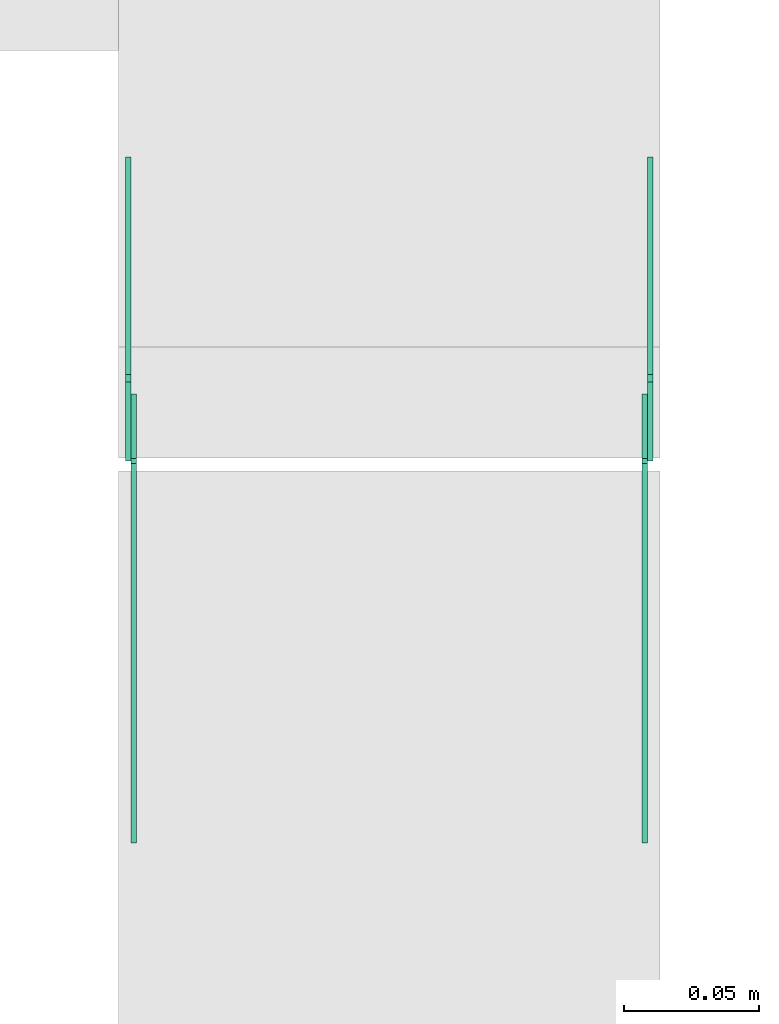
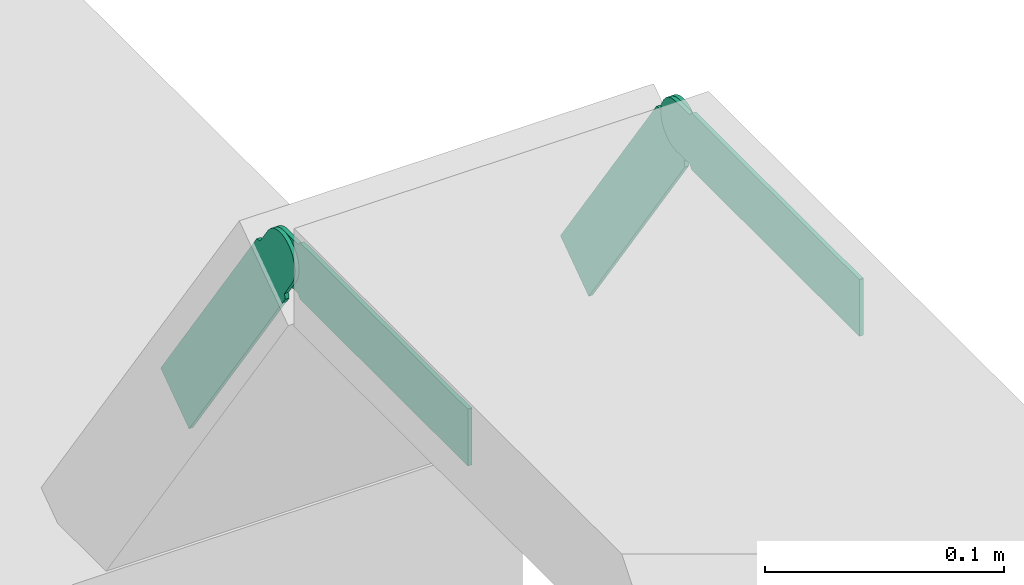
# One storey, part 26 of 28: 4 flow fittings.
"""IFC2X3 building model written with IfcOpenShell, lengths in millimetres."""

import ifcopenshell
import ifcopenshell.guid

model = None  # the IFC model being written
_history = None  # IfcOwnerHistory: only IFC2X3 demands one
_inside = {}  # id of a spatial element -> (the spatial element, [elements in it])
_under = {}  # id of a project, library or spatial element -> (it, [spatial elements below it])
_declared = {}  # id of a project -> (the project, [libraries it declares])
_typed = {}  # id of a type object -> (the type object, [elements of that type])
_made_of = {}  # id of a material, layer set ... -> (it, [elements and type objects made of it])


def new_model(schema):
    """Start an empty IFC model of exactly this schema.

    Asked for "IFC4X3", IfcOpenShell would pick the latest addendum, in which some entities
    have other attributes; the version numbers below select the first issue.
    IFC2X3 requires an IfcOwnerHistory on every rooted entity: one is made here for all.
    """
    global model, _history
    if schema == "IFC4X3":
        model = ifcopenshell.file(schema_version=(4, 3, 0, 0))
    else:
        model = ifcopenshell.file(schema=schema)
    _inside.clear()
    _under.clear()
    _declared.clear()
    _typed.clear()
    _made_of.clear()
    _history = None
    if model.schema == "IFC2X3":
        org = make("IfcOrganization", Name="unknown")
        user = make(
            "IfcPersonAndOrganization",
            ThePerson=make("IfcPerson", FamilyName="unknown"),
            TheOrganization=org,
        )
        app = make(
            "IfcApplication",
            ApplicationDeveloper=org,
            Version="unknown",
            ApplicationFullName="unknown",
            ApplicationIdentifier="unknown",
        )
        _history = make(
            "IfcOwnerHistory",
            OwningUser=user,
            OwningApplication=app,
            ChangeAction="ADDED",
            CreationDate=0,
        )
    return model


def make(cls, **values):
    """One entity of the class cls with the attributes given. An attribute that is None is left unset."""
    return model.create_entity(
        cls, **{name: value for name, value in values.items() if value is not None}
    )


def entity(cls, *values):
    """Any entity or typed value of the class cls, its attributes in the order of the schema. None: left unset."""
    e = model.create_entity(cls)
    for i, value in enumerate(values):
        if value is not None:
            e[i] = value
    return e


def rooted(cls, **values):
    """An entity with a GlobalId (a new one), such as an element, a storey or a relation."""
    return make(cls, GlobalId=ifcopenshell.guid.new(), OwnerHistory=_history, **values)


def si_unit(unit_type, name, prefix=None):
    """IfcSIUnit, for example si_unit("LENGTHUNIT", "METRE", prefix="MILLI")."""
    return make("IfcSIUnit", UnitType=unit_type, Prefix=prefix, Name=name)


def converted_unit(unit_type, name, factor, base, dimensions=None, offset=None):
    """IfcConversionBasedUnit, such as the inch: factor (a typed value) times the base unit."""
    return make(
        "IfcConversionBasedUnit"
        if offset is None
        else "IfcConversionBasedUnitWithOffset",
        ConversionOffset=offset,
        Dimensions=None
        if dimensions is None
        else entity("IfcDimensionalExponents", *dimensions),
        UnitType=unit_type,
        Name=name,
        ConversionFactor=make(
            "IfcMeasureWithUnit", ValueComponent=factor, UnitComponent=base
        ),
    )


def derived_unit(unit_type, elements):
    """IfcDerivedUnit: a product of units, each with its exponent."""
    return make(
        "IfcDerivedUnit",
        Elements=[
            make("IfcDerivedUnitElement", Unit=unit, Exponent=power)
            for unit, power in elements
        ],
        UnitType=unit_type,
    )


def assignment(units):
    """IfcUnitAssignment: the units of a project."""
    return None if units is None else make("IfcUnitAssignment", Units=units)


def point(xyz):
    """IfcCartesianPoint."""
    return None if xyz is None else make("IfcCartesianPoint", Coordinates=xyz)


def direction(xyz):
    """IfcDirection."""
    return None if xyz is None else make("IfcDirection", DirectionRatios=xyz)


def frame(location, z_axis=None, x_axis=None):
    """IfcAxis2Placement3D, a coordinate frame: its origin and axes. An axis left out is left unset."""
    return make(
        "IfcAxis2Placement3D",
        Location=point(location),
        Axis=direction(z_axis),
        RefDirection=direction(x_axis),
    )


def frame_2d(location, x_axis=None):
    """IfcAxis2Placement2D, a coordinate frame in the plane: its origin and x axis."""
    return make(
        "IfcAxis2Placement2D", Location=point(location), RefDirection=direction(x_axis)
    )


def origin():
    """The frame at (0, 0, 0) with its axes left unset."""
    return frame((0.0, 0.0, 0.0))


def place(relative_to, where):
    """IfcLocalPlacement: puts the frame where relative to a parent placement (None: the world)."""
    return make(
        "IfcLocalPlacement", PlacementRelTo=relative_to, RelativePlacement=where
    )


def context(
    kind, dimensions, precision=None, world=None, true_north=None, identifier=None
):
    """IfcGeometricRepresentationContext, for example the 3D "Model" context."""
    return make(
        "IfcGeometricRepresentationContext",
        ContextIdentifier=identifier,
        ContextType=kind,
        CoordinateSpaceDimension=dimensions,
        Precision=precision,
        WorldCoordinateSystem=world,
        TrueNorth=true_north,
    )


def subcontext(parent, identifier, kind, view, scale=None):
    """IfcGeometricRepresentationSubContext, for example "Body" below "Model"."""
    return make(
        "IfcGeometricRepresentationSubContext",
        ContextIdentifier=identifier,
        ContextType=kind,
        ParentContext=parent,
        TargetScale=scale,
        TargetView=view,
    )


def project(units=None, contexts=None):
    """IfcProject with its units and contexts."""
    return rooted(
        "IfcProject",
        Name="project",
        RepresentationContexts=contexts,
        UnitsInContext=assignment(units),
    )


def spatial(cls, under=None, at=None, **own):
    """A site, building, storey or space (cls), placed at a placement, below another one or the project."""
    s = rooted(cls, ObjectPlacement=at, **own)
    if under is not None:
        _under.setdefault(under.id(), (under, []))[1].append(s)
    return s


def polyline(points):
    """IfcPolyline through the points."""
    return make("IfcPolyline", Points=[point(p) for p in points])


def circle_curve(where, radius):
    """IfcCircle in the frame where."""
    return make("IfcCircle", Position=where, Radius=radius)


def parameter(value):
    """IfcParameterValue: where a trimmed curve begins or ends, as a parameter of its basis curve."""
    return model.create_entity("IfcParameterValue", value)


def trimmed(basis, trim1, trim2, sense, master):
    """IfcTrimmedCurve: the piece of a basis curve between two trims."""
    return make(
        "IfcTrimmedCurve",
        BasisCurve=basis,
        Trim1=trim1,
        Trim2=trim2,
        SenseAgreement=sense,
        MasterRepresentation=master,
    )


def segment(curve, same_sense, transition):
    """IfcCompositeCurveSegment."""
    return make(
        "IfcCompositeCurveSegment",
        Transition=transition,
        SameSense=same_sense,
        ParentCurve=curve,
    )


def composite_curve(segments, self_intersect=None):
    """IfcCompositeCurve: segments joined end to end."""
    return make("IfcCompositeCurve", Segments=segments, SelfIntersect=self_intersect)


def outline(outer, holes=None, kind="AREA"):
    """IfcArbitraryClosedProfileDef: a profile drawn as a closed curve; with holes, ...WithVoids."""
    if holes is None:
        return make("IfcArbitraryClosedProfileDef", ProfileType=kind, OuterCurve=outer)
    return make(
        "IfcArbitraryProfileDefWithVoids",
        ProfileType=kind,
        OuterCurve=outer,
        InnerCurves=holes,
    )


def extrude(swept, where, along, depth):
    """IfcExtrudedAreaSolid: the profile swept, set in the frame where, extruded along a direction by depth."""
    return make(
        "IfcExtrudedAreaSolid",
        SweptArea=swept,
        Position=where,
        ExtrudedDirection=direction(along),
        Depth=depth,
    )


def shape(context_of_items, identifier, shape_type, items):
    """IfcShapeRepresentation: the items that make up one representation, for example the "Body"."""
    return make(
        "IfcShapeRepresentation",
        ContextOfItems=context_of_items,
        RepresentationIdentifier=identifier,
        RepresentationType=shape_type,
        Items=items,
    )


def source(mapping_origin, context_of_items, identifier, shape_type, items):
    """IfcRepresentationMap: a shape defined once, which mapped items show again and again."""
    return make(
        "IfcRepresentationMap",
        MappingOrigin=mapping_origin,
        MappedRepresentation=shape(context_of_items, identifier, shape_type, items),
    )


def transform(
    local_origin,
    x_axis=None,
    y_axis=None,
    z_axis=None,
    scale=None,
    scale2=None,
    scale3=None,
    uniform=True,
):
    """IfcCartesianTransformationOperator3D, or its non-uniform kind. x_axis, y_axis, z_axis: its Axis1, 2, 3."""
    if uniform:
        return make(
            "IfcCartesianTransformationOperator3D",
            Axis1=direction(x_axis),
            Axis2=direction(y_axis),
            LocalOrigin=point(local_origin),
            Scale=scale,
            Axis3=direction(z_axis),
        )
    return make(
        "IfcCartesianTransformationOperator3DnonUniform",
        Axis1=direction(x_axis),
        Axis2=direction(y_axis),
        LocalOrigin=point(local_origin),
        Scale=scale,
        Axis3=direction(z_axis),
        Scale2=scale2,
        Scale3=scale3,
    )


def mapped(mapping_source, mapping_target):
    """IfcMappedItem: shows the shape of a source again, moved by a transform."""
    return make(
        "IfcMappedItem", MappingSource=mapping_source, MappingTarget=mapping_target
    )


def material(Name=None, Category=None):
    """IfcMaterial."""
    return make("IfcMaterial", Name=Name, Category=Category)


def made_of(thing, what):
    """Note that an element or type object is made of a material, layer set ...; save() writes the relation."""
    if what is not None:
        _made_of.setdefault(what.id(), (what, []))[1].append(thing)
    return thing


def type_object(cls, material=None, **own):
    """A type object (cls), such as IfcWallType, which elements share."""
    return made_of(rooted(cls, **own), material)


def type_shapes(of_type, sources):
    """Give a type object the sources (RepresentationMaps) that its elements show as mapped items."""
    of_type.RepresentationMaps = sources


def element(
    cls,
    number,
    at=None,
    inside=None,
    cuts=None,
    type_object=None,
    material=None,
    context=None,
    identifier="Body",
    shape_type=None,
    held_by="IfcProductDefinitionShape",
    body=None,
    shapes=None,
    **own,
):
    """One element of the class cls, such as IfcWall. Its Tag is "e" and its number.

    at: its placement. inside: the storey or other place that contains it. cuts: it is an
    opening in that element (IfcRelVoidsElement). A single representation is given by context,
    identifier, shape_type and body (its items); several are given by shapes. held_by: the class
    of the entity that holds the representations. save() writes the other relations.
    """
    e = rooted(cls, Tag="e%d" % number, ObjectPlacement=at, **own)
    if body is not None:
        shapes = [shape(context, identifier, shape_type, body)]
    if shapes is not None:
        e.Representation = make(held_by, Representations=shapes)
    if inside is not None:
        _inside.setdefault(inside.id(), (inside, []))[1].append(e)
    if cuts is not None:
        rooted(
            "IfcRelVoidsElement", RelatingBuildingElement=cuts, RelatedOpeningElement=e
        )
    if type_object is not None:
        _typed.setdefault(type_object.id(), (type_object, []))[1].append(e)
    return made_of(e, material)


def aggregate(whole, parts):
    """IfcRelAggregates: a whole, such as a stair, and the parts it consists of."""
    return rooted("IfcRelAggregates", RelatingObject=whole, RelatedObjects=parts)


def save(model, path):
    """Write the relations noted so far, then the file.

    IfcRelAggregates (storeys below a building ...), IfcRelContainedInSpatialStructure (elements
    in a storey), IfcRelDefinesByType, IfcRelAssociatesMaterial and IfcRelDeclares: one each for
    every whole, place, type object, material and project.
    """
    for whole, parts in _under.values():
        aggregate(whole, parts)
    for where, things in _inside.values():
        rooted(
            "IfcRelContainedInSpatialStructure",
            RelatedElements=things,
            RelatingStructure=where,
        )
    for kind, things in _typed.values():
        rooted("IfcRelDefinesByType", RelatedObjects=things, RelatingType=kind)
    for what, things in _made_of.values():
        rooted("IfcRelAssociatesMaterial", RelatedObjects=things, RelatingMaterial=what)
    for by, libraries in _declared.values():
        rooted("IfcRelDeclares", RelatingContext=by, RelatedDefinitions=libraries)
    model.write(path)


model = new_model("IFC2X3")

# Units and contexts
model_context = context("Model", 3, precision=0.01, world=origin(), true_north=direction((6.12303176911189e-17, 1.0)))
body_context = subcontext(model_context, "Body", "Model", "MODEL_VIEW")
ifc_project = project(units=[si_unit("LENGTHUNIT", "METRE", prefix="MILLI"), si_unit("AREAUNIT", "SQUARE_METRE"), si_unit("VOLUMEUNIT", "CUBIC_METRE"), converted_unit("PLANEANGLEUNIT", "DEGREE", entity("IfcRatioMeasure", 0.0174532925199433), si_unit("PLANEANGLEUNIT", "RADIAN"), dimensions=[0, 0, 0, 0, 0, 0, 0]), si_unit("MASSUNIT", "GRAM", prefix="KILO"), derived_unit("MASSDENSITYUNIT", [(si_unit("MASSUNIT", "GRAM", prefix="KILO"), 1), (si_unit("LENGTHUNIT", "METRE"), -3)]), derived_unit("MOMENTOFINERTIAUNIT", [(si_unit("LENGTHUNIT", "METRE"), 4)]), si_unit("TIMEUNIT", "SECOND"), si_unit("FREQUENCYUNIT", "HERTZ"), si_unit("THERMODYNAMICTEMPERATUREUNIT", "DEGREE_CELSIUS"), derived_unit("THERMALTRANSMITTANCEUNIT", [(si_unit("MASSUNIT", "GRAM", prefix="KILO"), 1), (si_unit("THERMODYNAMICTEMPERATUREUNIT", "KELVIN"), -1), (si_unit("TIMEUNIT", "SECOND"), -3)]), derived_unit("VOLUMETRICFLOWRATEUNIT", [(si_unit("LENGTHUNIT", "METRE"), 3), (si_unit("TIMEUNIT", "SECOND"), -1)]), derived_unit("MASSFLOWRATEUNIT", [(si_unit("MASSUNIT", "GRAM", prefix="KILO"), 1), (si_unit("TIMEUNIT", "SECOND"), -1)]), derived_unit("ROTATIONALFREQUENCYUNIT", [(si_unit("TIMEUNIT", "SECOND"), -1)]), si_unit("ELECTRICCURRENTUNIT", "AMPERE"), si_unit("ELECTRICVOLTAGEUNIT", "VOLT"), si_unit("POWERUNIT", "WATT"), si_unit("FORCEUNIT", "NEWTON", prefix="KILO"), si_unit("ILLUMINANCEUNIT", "LUX"), si_unit("LUMINOUSFLUXUNIT", "LUMEN"), si_unit("LUMINOUSINTENSITYUNIT", "CANDELA"), derived_unit("USERDEFINED", [(si_unit("MASSUNIT", "GRAM", prefix="KILO"), -1), (si_unit("LENGTHUNIT", "METRE"), -2), (si_unit("TIMEUNIT", "SECOND"), 3), (si_unit("LUMINOUSFLUXUNIT", "LUMEN"), 1)]), derived_unit("LINEARVELOCITYUNIT", [(si_unit("LENGTHUNIT", "METRE"), 1), (si_unit("TIMEUNIT", "SECOND"), -1)]), si_unit("PRESSUREUNIT", "PASCAL"), derived_unit("USERDEFINED", [(si_unit("LENGTHUNIT", "METRE"), -2), (si_unit("MASSUNIT", "GRAM", prefix="KILO"), 1), (si_unit("TIMEUNIT", "SECOND"), -2)]), derived_unit("LINEARFORCEUNIT", [(si_unit("MASSUNIT", "GRAM", prefix="KILO"), 1), (si_unit("LENGTHUNIT", "METRE"), 1), (si_unit("TIMEUNIT", "SECOND"), -2), (si_unit("LENGTHUNIT", "METRE"), -1)]), derived_unit("PLANARFORCEUNIT", [(si_unit("MASSUNIT", "GRAM", prefix="KILO"), 1), (si_unit("LENGTHUNIT", "METRE"), 1), (si_unit("TIMEUNIT", "SECOND"), -2), (si_unit("LENGTHUNIT", "METRE"), -2)])], contexts=[model_context])

# Site, building, storey
site_placement = place(None, frame((0.0, -0.00077364408347762, 0.0)))
site = spatial("IfcSite", under=ifc_project, at=site_placement, CompositionType="ELEMENT")
building_placement = place(site_placement, origin())
building = spatial("IfcBuilding", under=site, at=building_placement, CompositionType="ELEMENT")
storey_placement = place(building_placement, origin())
storey = spatial("IfcBuildingStorey", under=building, at=storey_placement, CompositionType="ELEMENT", Elevation=0.0)

# Flow fittings
ifc_material = material(Name="G")
cable_carrier_fitting_type_1 = type_object("IfcCableCarrierFittingType", PredefinedType="NOTDEFINED", material=ifc_material)
shared_shape_1 = source(origin(), body_context, "Body", "SweptSolid", [
    extrude(outline(composite_curve([segment(trimmed(circle_curve(frame_2d((-44.5901162790698, 0.0), x_axis=(1.0, 0.0)), 12.5), [parameter(90.0000000000007)], [parameter(270.0)], True, "PARAMETER"), True, "CONTINUOUS"), segment(polyline([(-44.5901162790697, -12.5), (-33.0901162790698, -12.5)]), True, "CONTINUOUS"), segment(polyline([(-33.0901162790698, -12.5), (-31.2296511627907, -14.5)]), True, "CONTINUOUS"), segment(polyline([(-31.2296511627907, -14.5), (108.90988372093, -14.5)]), True, "CONTINUOUS"), segment(polyline([(108.90988372093, -14.5), (108.90988372093, 14.5)]), True, "CONTINUOUS"), segment(polyline([(108.90988372093, 14.5), (-31.2296511627907, 14.5)]), True, "CONTINUOUS"), segment(polyline([(-31.2296511627907, 14.5), (-33.0901162790698, 12.5)]), True, "CONTINUOUS"), segment(polyline([(-33.0901162790698, 12.5), (-44.5901162790699, 12.5)]), True, "CONTINUOUS")], self_intersect=False)), frame((44.5901162790698, 0.0, 0.0), z_axis=(0.0, 0.0, -1.0), x_axis=(1.0, 0.0, 0.0)), (0.0, 0.0, -1.0), 2.0),
])
type_shapes(cable_carrier_fitting_type_1, [shared_shape_1])
flow_fitting_1_placement = place(storey_placement, frame((63906.7249606143, 19260.607382489, 2825.0), z_axis=(-1.0, 0.0, 0.0), x_axis=(0.0, 0.57357643635105, -0.819152044288989)))
element("IfcFlowFitting", 1, at=flow_fitting_1_placement, inside=storey, type_object=cable_carrier_fitting_type_1, material=ifc_material, context=body_context, shape_type="MappedRepresentation", body=[
    mapped(shared_shape_1, transform((0.0, 0.0, 0.0), scale=1.0)),
])
cable_carrier_fitting_type_2 = type_object("IfcCableCarrierFittingType", PredefinedType="NOTDEFINED", material=ifc_material)
shared_shape_2 = source(origin(), body_context, "Body", "SweptSolid", [
    extrude(outline(composite_curve([segment(trimmed(circle_curve(frame_2d((-44.5901162790697, 0.0), x_axis=(1.0, 0.0)), 12.5), [parameter(90.0000000000007)], [parameter(270.0)], True, "PARAMETER"), True, "CONTINUOUS"), segment(polyline([(-44.5901162790697, -12.5), (-33.0901162790697, -12.5)]), True, "CONTINUOUS"), segment(polyline([(-33.0901162790697, -12.5), (-31.2296511627907, -14.5)]), True, "CONTINUOUS"), segment(polyline([(-31.2296511627907, -14.5), (108.90988372093, -14.5)]), True, "CONTINUOUS"), segment(polyline([(108.90988372093, -14.5), (108.90988372093, 14.5)]), True, "CONTINUOUS"), segment(polyline([(108.90988372093, 14.5), (-31.2296511627907, 14.5)]), True, "CONTINUOUS"), segment(polyline([(-31.2296511627907, 14.5), (-33.0901162790698, 12.5)]), True, "CONTINUOUS"), segment(polyline([(-33.0901162790698, 12.5), (-44.5901162790699, 12.5)]), True, "CONTINUOUS")], self_intersect=False)), frame((44.5901162790697, 0.0, 0.0)), (0.0, 0.0, 1.0), 2.0),
])
type_shapes(cable_carrier_fitting_type_2, [shared_shape_2])
flow_fitting_2_placement = place(storey_placement, frame((64097.6449606346, 19260.607382489, 2825.0), z_axis=(1.0, 0.0, 0.0), x_axis=(0.0, 0.57357643635105, -0.819152044288989)))
element("IfcFlowFitting", 2, at=flow_fitting_2_placement, inside=storey, type_object=cable_carrier_fitting_type_2, material=ifc_material, context=body_context, shape_type="MappedRepresentation", body=[
    mapped(shared_shape_2, transform((0.0, 0.0, 0.0), scale=1.0)),
])
cable_carrier_fitting_type_3 = type_object("IfcCableCarrierFittingType", PredefinedType="NOTDEFINED", material=ifc_material)
shared_shape_3 = source(origin(), body_context, "Body", "SweptSolid", [
    extrude(outline(composite_curve([segment(trimmed(circle_curve(frame_2d((-44.5901162790698, 0.0), x_axis=(1.0, 0.0)), 12.5), [parameter(90.0000000000007)], [parameter(270.0)], True, "PARAMETER"), True, "CONTINUOUS"), segment(polyline([(-44.5901162790697, -12.5), (-33.0901162790698, -12.5)]), True, "CONTINUOUS"), segment(polyline([(-33.0901162790698, -12.5), (-31.2296511627907, -14.5)]), True, "CONTINUOUS"), segment(polyline([(-31.2296511627907, -14.5), (108.90988372093, -14.5)]), True, "CONTINUOUS"), segment(polyline([(108.90988372093, -14.5), (108.90988372093, 14.5)]), True, "CONTINUOUS"), segment(polyline([(108.90988372093, 14.5), (-31.2296511627907, 14.5)]), True, "CONTINUOUS"), segment(polyline([(-31.2296511627907, 14.5), (-33.0901162790698, 12.5)]), True, "CONTINUOUS"), segment(polyline([(-33.0901162790698, 12.5), (-44.5901162790699, 12.5)]), True, "CONTINUOUS")], self_intersect=False)), frame((44.5901162790698, 0.0, 0.0), z_axis=(0.0, 0.0, -1.0), x_axis=(1.0, 0.0, 0.0)), (0.0, 0.0, -1.0), 2.0),
])
type_shapes(cable_carrier_fitting_type_3, [shared_shape_3])
flow_fitting_3_placement = place(storey_placement, frame((64095.6449606346, 19260.607382489, 2825.0), z_axis=(1.0, 0.0, 0.0), x_axis=(0.0, -1.0, 0.0)))
element("IfcFlowFitting", 3, at=flow_fitting_3_placement, inside=storey, type_object=cable_carrier_fitting_type_3, material=ifc_material, context=body_context, shape_type="MappedRepresentation", body=[
    mapped(shared_shape_3, transform((0.0, 0.0, 0.0), scale=1.0)),
])
cable_carrier_fitting_type_4 = type_object("IfcCableCarrierFittingType", PredefinedType="NOTDEFINED", material=ifc_material)
shared_shape_4 = source(origin(), body_context, "Body", "SweptSolid", [
    extrude(outline(composite_curve([segment(trimmed(circle_curve(frame_2d((-44.5901162790697, 0.0), x_axis=(1.0, 0.0)), 12.5), [parameter(90.0000000000007)], [parameter(270.0)], True, "PARAMETER"), True, "CONTINUOUS"), segment(polyline([(-44.5901162790697, -12.5), (-33.0901162790697, -12.5)]), True, "CONTINUOUS"), segment(polyline([(-33.0901162790697, -12.5), (-31.2296511627907, -14.5)]), True, "CONTINUOUS"), segment(polyline([(-31.2296511627907, -14.5), (108.90988372093, -14.5)]), True, "CONTINUOUS"), segment(polyline([(108.90988372093, -14.5), (108.90988372093, 14.5)]), True, "CONTINUOUS"), segment(polyline([(108.90988372093, 14.5), (-31.2296511627907, 14.5)]), True, "CONTINUOUS"), segment(polyline([(-31.2296511627907, 14.5), (-33.0901162790698, 12.5)]), True, "CONTINUOUS"), segment(polyline([(-33.0901162790698, 12.5), (-44.5901162790699, 12.5)]), True, "CONTINUOUS")], self_intersect=False)), frame((44.5901162790697, 0.0, 0.0)), (0.0, 0.0, 1.0), 2.0),
])
type_shapes(cable_carrier_fitting_type_4, [shared_shape_4])
flow_fitting_4_placement = place(storey_placement, frame((63908.7249606143, 19260.607382489, 2825.0), z_axis=(-1.0, 0.0, 0.0), x_axis=(0.0, -1.0, 0.0)))
element("IfcFlowFitting", 4, at=flow_fitting_4_placement, inside=storey, type_object=cable_carrier_fitting_type_4, material=ifc_material, context=body_context, shape_type="MappedRepresentation", body=[
    mapped(shared_shape_4, transform((0.0, 0.0, 0.0), scale=1.0)),
])

save(model, "model.ifc")
